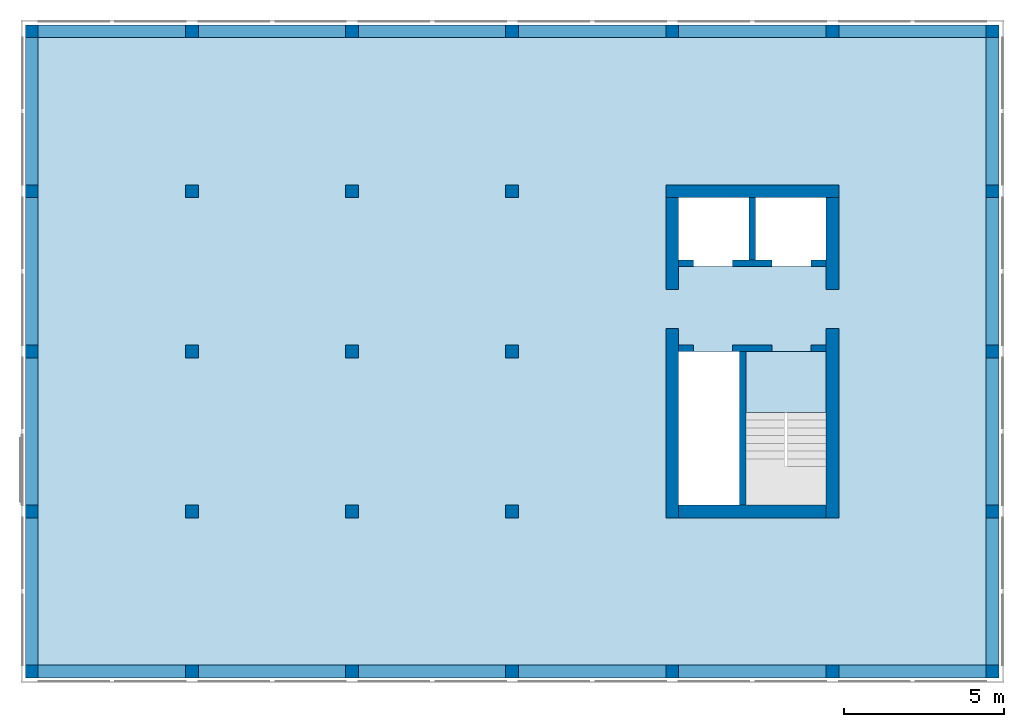
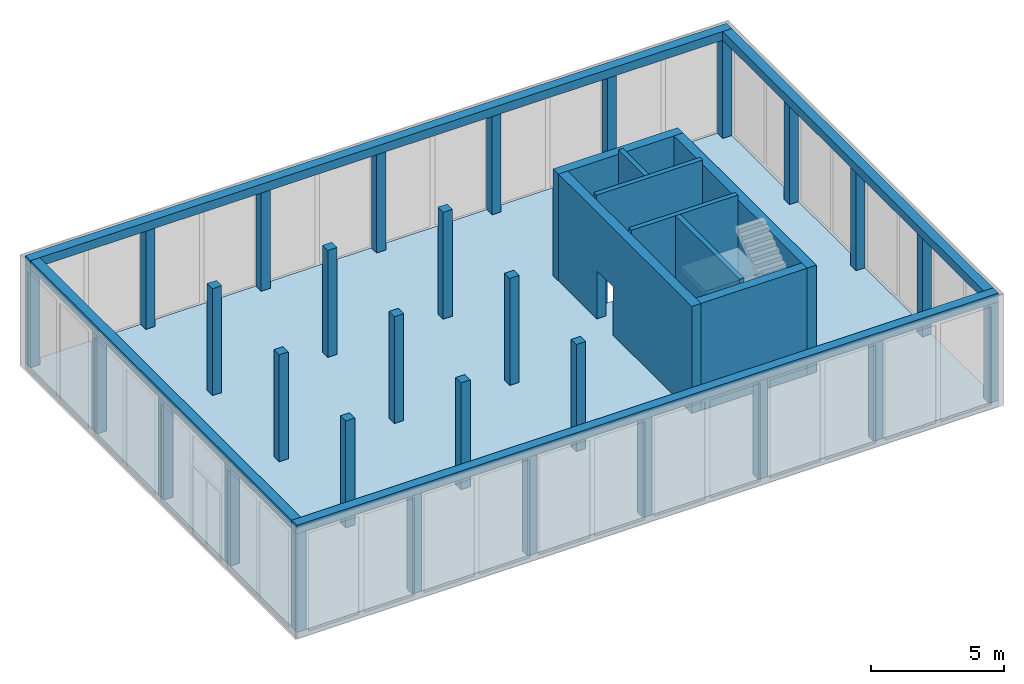
# One storey, part 1 of 5: 29 columns, 8 walls, 4 beams, 2 slabs, 9 openings.
"""IFC2X3 building model written with IfcOpenShell, lengths in metres."""

from ifc_helpers import new_model, entity, si_unit, converted_unit, frame, frame_2d, origin, origin_with_axes, place, context, subcontext, project, spatial, polyline, rectangle, outline, extrude, material, layer, layer_set, layer_usage, element, save


model = new_model("IFC2X3")

# Units and contexts
model_context = context("Model", 3, precision=1e-05, world=origin())
body_context = subcontext(model_context, "Body", "Model", "MODEL_VIEW")
ifc_project = project(units=[si_unit("LENGTHUNIT", "METRE"), si_unit("AREAUNIT", "SQUARE_METRE"), si_unit("VOLUMEUNIT", "CUBIC_METRE"), si_unit("MASSUNIT", "GRAM", prefix="KILO"), converted_unit("PLANEANGLEUNIT", "DEGREE", entity("IfcPlaneAngleMeasure", 0.0174532925199433), si_unit("PLANEANGLEUNIT", "RADIAN"), dimensions=[0, 0, 0, 0, 0, 0, 0])], contexts=[model_context])

# Site, building, storey
site_placement = place(None, origin())
site = spatial("IfcSite", under=ifc_project, at=site_placement, CompositionType="ELEMENT")
building_placement = place(site_placement, origin())
building = spatial("IfcBuilding", under=site, at=building_placement, CompositionType="ELEMENT")
storey_placement = place(building_placement, frame((0.0, 0.0, -0.2)))
storey = spatial("IfcBuildingStorey", under=building, at=storey_placement, Name="Erdgeschoss", CompositionType="ELEMENT", Elevation=-0.2)

# Columns
ifc_material_1 = material(Name="C30/37")
column_1_placement = place(storey_placement, frame((30.0, 15.0, 0.0)))
element("IfcColumn", 1, at=column_1_placement, inside=storey, material=ifc_material_1, context=body_context, shape_type="SweptSolid", body=[
    extrude(rectangle(XDim=0.4, YDim=0.4, at=frame_2d((0.2, 0.2), x_axis=(1.0, 0.0))), origin_with_axes(), (0.0, 0.0, 1.0), 4.5),
])
ifc_material_2 = material(Name="C30/37")
column_2_placement = place(storey_placement, frame((25.0, 0.0, 0.0)))
element("IfcColumn", 2, at=column_2_placement, inside=storey, material=ifc_material_2, context=body_context, shape_type="SweptSolid", body=[
    extrude(rectangle(XDim=0.4, YDim=0.4, at=frame_2d((0.2, 0.2), x_axis=(1.0, 0.0))), origin_with_axes(), (0.0, 0.0, 1.0), 4.5),
])
ifc_material_3 = material(Name="C30/37")
column_3_placement = place(storey_placement, frame((20.0, 0.0, 0.0)))
element("IfcColumn", 3, at=column_3_placement, inside=storey, material=ifc_material_3, context=body_context, shape_type="SweptSolid", body=[
    extrude(rectangle(XDim=0.4, YDim=0.4, at=frame_2d((0.2, 0.2), x_axis=(1.0, 0.0))), origin_with_axes(), (0.0, 0.0, 1.0), 4.5),
])
ifc_material_4 = material(Name="C30/37")
column_4_placement = place(storey_placement, frame((15.0, 0.0, 0.0)))
element("IfcColumn", 4, at=column_4_placement, inside=storey, material=ifc_material_4, context=body_context, shape_type="SweptSolid", body=[
    extrude(rectangle(XDim=0.4, YDim=0.4, at=frame_2d((0.2, 0.2), x_axis=(1.0, 0.0))), origin_with_axes(), (0.0, 0.0, 1.0), 4.5),
])
ifc_material_5 = material(Name="C30/37")
column_5_placement = place(storey_placement, frame((10.0, 0.0, 0.0)))
element("IfcColumn", 5, at=column_5_placement, inside=storey, material=ifc_material_5, context=body_context, shape_type="SweptSolid", body=[
    extrude(rectangle(XDim=0.4, YDim=0.4, at=frame_2d((0.2, 0.2), x_axis=(1.0, 0.0))), origin_with_axes(), (0.0, 0.0, 1.0), 4.5),
])
ifc_material_6 = material(Name="C30/37")
column_6_placement = place(storey_placement, frame((5.0, 0.0, 0.0)))
element("IfcColumn", 6, at=column_6_placement, inside=storey, material=ifc_material_6, context=body_context, shape_type="SweptSolid", body=[
    extrude(rectangle(XDim=0.4, YDim=0.4, at=frame_2d((0.2, 0.2), x_axis=(1.0, 0.0))), origin_with_axes(), (0.0, 0.0, 1.0), 4.5),
])
ifc_material_7 = material(Name="C30/37")
column_7_placement = place(storey_placement, frame((30.0, 10.0, 0.0)))
element("IfcColumn", 7, at=column_7_placement, inside=storey, material=ifc_material_7, context=body_context, shape_type="SweptSolid", body=[
    extrude(rectangle(XDim=0.4, YDim=0.4, at=frame_2d((0.2, 0.2), x_axis=(1.0, 0.0))), origin_with_axes(), (0.0, 0.0, 1.0), 4.5),
])
ifc_material_8 = material(Name="C30/37")
column_8_placement = place(storey_placement, frame((30.0, 5.0, 0.0)))
element("IfcColumn", 8, at=column_8_placement, inside=storey, material=ifc_material_8, context=body_context, shape_type="SweptSolid", body=[
    extrude(rectangle(XDim=0.4, YDim=0.4, at=frame_2d((0.2, 0.2), x_axis=(1.0, 0.0))), origin_with_axes(), (0.0, 0.0, 1.0), 4.5),
])
ifc_material_9 = material(Name="C30/37")
column_9_placement = place(storey_placement, origin())
element("IfcColumn", 9, at=column_9_placement, inside=storey, material=ifc_material_9, context=body_context, shape_type="SweptSolid", body=[
    extrude(rectangle(XDim=0.4, YDim=0.4, at=frame_2d((0.2, 0.2), x_axis=(1.0, 0.0))), origin_with_axes(), (0.0, 0.0, 1.0), 4.5),
])
ifc_material_10 = material(Name="C30/37")
column_10_placement = place(storey_placement, frame((0.0, 15.0, 0.0)))
element("IfcColumn", 10, at=column_10_placement, inside=storey, material=ifc_material_10, context=body_context, shape_type="SweptSolid", body=[
    extrude(rectangle(XDim=0.4, YDim=0.4, at=frame_2d((0.2, 0.2), x_axis=(1.0, 0.0))), origin_with_axes(), (0.0, 0.0, 1.0), 4.5),
])
ifc_material_11 = material(Name="C30/37")
column_11_placement = place(storey_placement, frame((0.0, 5.0, 0.0)))
element("IfcColumn", 11, at=column_11_placement, inside=storey, material=ifc_material_11, context=body_context, shape_type="SweptSolid", body=[
    extrude(rectangle(XDim=0.4, YDim=0.4, at=frame_2d((0.2, 0.2), x_axis=(1.0, 0.0))), origin_with_axes(), (0.0, 0.0, 1.0), 4.5),
])
ifc_material_12 = material(Name="C30/37")
column_12_placement = place(storey_placement, frame((-1.27897692436818e-15, 10.0, 0.0)))
element("IfcColumn", 12, at=column_12_placement, inside=storey, material=ifc_material_12, context=body_context, shape_type="SweptSolid", body=[
    extrude(rectangle(XDim=0.400000000000003, YDim=0.4, at=frame_2d((0.200000000000001, 0.2), x_axis=(1.0, 0.0))), origin_with_axes(), (0.0, 0.0, 1.0), 4.5),
])
ifc_material_13 = material(Name="C30/37")
column_13_placement = place(storey_placement, frame((0.0, 20.0, 0.0)))
element("IfcColumn", 13, at=column_13_placement, inside=storey, material=ifc_material_13, context=body_context, shape_type="SweptSolid", body=[
    extrude(rectangle(XDim=0.4, YDim=0.4, at=frame_2d((0.2, 0.2), x_axis=(1.0, 0.0))), origin_with_axes(), (0.0, 0.0, 1.0), 4.5),
])
ifc_material_14 = material(Name="C30/37")
column_14_placement = place(storey_placement, frame((30.0, 20.0, 0.0)))
element("IfcColumn", 14, at=column_14_placement, inside=storey, material=ifc_material_14, context=body_context, shape_type="SweptSolid", body=[
    extrude(rectangle(XDim=0.4, YDim=0.4, at=frame_2d((0.2, 0.2), x_axis=(1.0, 0.0))), origin_with_axes(), (0.0, 0.0, 1.0), 4.5),
])
ifc_material_15 = material(Name="C30/37")
column_15_placement = place(storey_placement, frame((10.0, 20.0, 0.0)))
element("IfcColumn", 15, at=column_15_placement, inside=storey, material=ifc_material_15, context=body_context, shape_type="SweptSolid", body=[
    extrude(rectangle(XDim=0.4, YDim=0.4, at=frame_2d((0.2, 0.2), x_axis=(1.0, 0.0))), origin_with_axes(), (0.0, 0.0, 1.0), 4.5),
])
ifc_material_16 = material(Name="C30/37")
column_16_placement = place(storey_placement, frame((25.0, 20.0, 0.0)))
element("IfcColumn", 16, at=column_16_placement, inside=storey, material=ifc_material_16, context=body_context, shape_type="SweptSolid", body=[
    extrude(rectangle(XDim=0.4, YDim=0.4, at=frame_2d((0.2, 0.2), x_axis=(1.0, 0.0))), origin_with_axes(), (0.0, 0.0, 1.0), 4.5),
])
ifc_material_17 = material(Name="C30/37")
column_17_placement = place(storey_placement, frame((20.0, 20.0, 0.0)))
element("IfcColumn", 17, at=column_17_placement, inside=storey, material=ifc_material_17, context=body_context, shape_type="SweptSolid", body=[
    extrude(rectangle(XDim=0.4, YDim=0.4, at=frame_2d((0.2, 0.2), x_axis=(1.0, 0.0))), origin_with_axes(), (0.0, 0.0, 1.0), 4.5),
])
ifc_material_18 = material(Name="C30/37")
column_18_placement = place(storey_placement, frame((15.0, 20.0, 0.0)))
element("IfcColumn", 18, at=column_18_placement, inside=storey, material=ifc_material_18, context=body_context, shape_type="SweptSolid", body=[
    extrude(rectangle(XDim=0.4, YDim=0.4, at=frame_2d((0.2, 0.2), x_axis=(1.0, 0.0))), origin_with_axes(), (0.0, 0.0, 1.0), 4.5),
])
ifc_material_19 = material(Name="C30/37")
column_19_placement = place(storey_placement, frame((10.0, 15.0, 0.0)))
element("IfcColumn", 19, at=column_19_placement, inside=storey, material=ifc_material_19, context=body_context, shape_type="SweptSolid", body=[
    extrude(rectangle(XDim=0.4, YDim=0.4, at=frame_2d((0.2, 0.2), x_axis=(1.0, 0.0))), origin_with_axes(), (0.0, 0.0, 1.0), 4.9),
])
ifc_material_20 = material(Name="C30/37")
column_20_placement = place(storey_placement, frame((5.0, 15.0, 0.0)))
element("IfcColumn", 20, at=column_20_placement, inside=storey, material=ifc_material_20, context=body_context, shape_type="SweptSolid", body=[
    extrude(rectangle(XDim=0.4, YDim=0.4, at=frame_2d((0.2, 0.2), x_axis=(1.0, 0.0))), origin_with_axes(), (0.0, 0.0, 1.0), 4.9),
])
ifc_material_21 = material(Name="C30/37")
column_21_placement = place(storey_placement, frame((15.0, 10.0, 0.0)))
element("IfcColumn", 21, at=column_21_placement, inside=storey, material=ifc_material_21, context=body_context, shape_type="SweptSolid", body=[
    extrude(rectangle(XDim=0.4, YDim=0.4, at=frame_2d((0.2, 0.2), x_axis=(1.0, 0.0))), origin_with_axes(), (0.0, 0.0, 1.0), 4.9),
])
ifc_material_22 = material(Name="C30/37")
column_22_placement = place(storey_placement, frame((10.0, 10.0, 0.0)))
element("IfcColumn", 22, at=column_22_placement, inside=storey, material=ifc_material_22, context=body_context, shape_type="SweptSolid", body=[
    extrude(rectangle(XDim=0.4, YDim=0.4, at=frame_2d((0.2, 0.2), x_axis=(1.0, 0.0))), origin_with_axes(), (0.0, 0.0, 1.0), 4.9),
])
ifc_material_23 = material(Name="C30/37")
column_23_placement = place(storey_placement, frame((5.0, 10.0, 0.0)))
element("IfcColumn", 23, at=column_23_placement, inside=storey, material=ifc_material_23, context=body_context, shape_type="SweptSolid", body=[
    extrude(rectangle(XDim=0.4, YDim=0.4, at=frame_2d((0.2, 0.2), x_axis=(1.0, 0.0))), origin_with_axes(), (0.0, 0.0, 1.0), 4.9),
])
ifc_material_24 = material(Name="C30/37")
column_24_placement = place(storey_placement, frame((15.0, 5.0, 0.0)))
element("IfcColumn", 24, at=column_24_placement, inside=storey, material=ifc_material_24, context=body_context, shape_type="SweptSolid", body=[
    extrude(rectangle(XDim=0.4, YDim=0.4, at=frame_2d((0.2, 0.2), x_axis=(1.0, 0.0))), origin_with_axes(), (0.0, 0.0, 1.0), 4.9),
])
ifc_material_25 = material(Name="C30/37")
column_25_placement = place(storey_placement, frame((10.0, 5.0, 0.0)))
element("IfcColumn", 25, at=column_25_placement, inside=storey, material=ifc_material_25, context=body_context, shape_type="SweptSolid", body=[
    extrude(rectangle(XDim=0.4, YDim=0.4, at=frame_2d((0.2, 0.2), x_axis=(1.0, 0.0))), origin_with_axes(), (0.0, 0.0, 1.0), 4.9),
])
ifc_material_26 = material(Name="C30/37")
column_26_placement = place(storey_placement, frame((5.0, 5.0, 0.0)))
element("IfcColumn", 26, at=column_26_placement, inside=storey, material=ifc_material_26, context=body_context, shape_type="SweptSolid", body=[
    extrude(rectangle(XDim=0.4, YDim=0.4, at=frame_2d((0.2, 0.2), x_axis=(1.0, 0.0))), origin_with_axes(), (0.0, 0.0, 1.0), 4.9),
])
ifc_material_27 = material(Name="C30/37")
column_27_placement = place(storey_placement, frame((15.0, 15.0, 0.0)))
element("IfcColumn", 27, at=column_27_placement, inside=storey, material=ifc_material_27, context=body_context, shape_type="SweptSolid", body=[
    extrude(rectangle(XDim=0.4, YDim=0.4, at=frame_2d((0.2, 0.2), x_axis=(1.0, 0.0))), origin_with_axes(), (0.0, 0.0, 1.0), 4.9),
])
ifc_material_28 = material(Name="C30/37")
column_28_placement = place(storey_placement, frame((30.0, -2.8421709430404e-17, 0.0)))
element("IfcColumn", 28, at=column_28_placement, inside=storey, material=ifc_material_28, context=body_context, shape_type="SweptSolid", body=[
    extrude(rectangle(XDim=0.4, YDim=0.4, at=frame_2d((0.2, 0.2), x_axis=(1.0, 0.0))), origin_with_axes(), (0.0, 0.0, 1.0), 4.5),
])
ifc_material_29 = material(Name="C30/37")
column_29_placement = place(storey_placement, frame((5.0, 20.0, 0.0)))
element("IfcColumn", 29, at=column_29_placement, inside=storey, material=ifc_material_29, context=body_context, shape_type="SweptSolid", body=[
    extrude(rectangle(XDim=0.4, YDim=0.4, at=frame_2d((0.2, 0.2), x_axis=(1.0, 0.0))), origin_with_axes(), (0.0, 0.0, 1.0), 4.5),
])

# Beams
ifc_material_30 = material(Name="C30/37")
beam_1_placement = place(storey_placement, frame((-2.8421709430404e-17, 20.0, 4.5)))
element("IfcBeam", 30, at=beam_1_placement, inside=storey, material=ifc_material_30, context=body_context, shape_type="SweptSolid", body=[
    extrude(rectangle(XDim=0.4, YDim=0.4, at=frame_2d((0.2, 0.2), x_axis=(1.0, 0.0))), frame((0.0, 0.0, 0.0), z_axis=(1.0, 0.0, 0.0), x_axis=(0.0, 1.0, 0.0)), (0.0, 0.0, 1.0), 30.4),
])
ifc_material_31 = material(Name="C30/37")
beam_2_placement = place(storey_placement, frame((2.95817792030736e-17, 2.8421709430404e-17, 4.5), z_axis=(0.0, 0.0, 1.0), x_axis=(1.0, -1.86984930463184e-18, 0.0)))
element("IfcBeam", 31, at=beam_2_placement, inside=storey, material=ifc_material_31, context=body_context, shape_type="SweptSolid", body=[
    extrude(rectangle(XDim=0.4, YDim=0.4, at=frame_2d((0.2, 0.2), x_axis=(1.0, 0.0))), frame((0.0, 0.0, 0.0), z_axis=(1.0, 0.0, 0.0), x_axis=(0.0, 1.0, 0.0)), (0.0, 0.0, 1.0), 30.4),
])
ifc_material_32 = material(Name="C30/37")
beam_3_placement = place(storey_placement, frame((-2.8421709430404e-17, 20.0, 4.5), z_axis=(0.0, 0.0, 1.0), x_axis=(2.90017443167388e-18, -1.0, 0.0)))
element("IfcBeam", 32, at=beam_3_placement, inside=storey, material=ifc_material_32, context=body_context, shape_type="SweptSolid", body=[
    extrude(rectangle(XDim=0.4, YDim=0.4, at=frame_2d((0.2, 0.2), x_axis=(1.0, 0.0))), frame((0.0, 0.0, 0.0), z_axis=(1.0, 0.0, 0.0), x_axis=(0.0, 1.0, 0.0)), (0.0, 0.0, 1.0), 19.6),
])
ifc_material_33 = material(Name="C30/37")
beam_4_placement = place(storey_placement, frame((30.4, 0.4, 4.5), z_axis=(0.0, 0.0, 1.0), x_axis=(0.0, 1.0, 0.0)))
element("IfcBeam", 33, at=beam_4_placement, inside=storey, material=ifc_material_33, context=body_context, shape_type="SweptSolid", body=[
    extrude(rectangle(XDim=0.4, YDim=0.4, at=frame_2d((0.2, 0.2), x_axis=(1.0, 0.0))), frame((0.0, 0.0, 0.0), z_axis=(1.0, 0.0, 0.0), x_axis=(0.0, 1.0, 0.0)), (0.0, 0.0, 1.0), 19.6),
])

# Slab, openings
ifc_material_34 = material(Name="C25/30")
slab_1_placement = place(storey_placement, frame((0.0, -2.8421709430404e-17, -0.3)))
slab_1 = element("IfcSlab", 34, at=slab_1_placement, inside=storey, material=ifc_material_34, Name="Geschossdecke", PredefinedType="FLOOR", context=body_context, shape_type="SweptSolid", body=[
    extrude(rectangle(XDim=30.4, YDim=20.4, at=frame_2d((15.2, 10.2), x_axis=(1.0, -9.34924652315921e-19))), frame((0.0, 2.8421709430404e-17, 0.0), z_axis=(0.0, 0.0, 1.0), x_axis=(1.0, 0.0, 0.0)), (0.0, 0.0, 1.0), 0.3),
])
opening_1_placement = place(slab_1_placement, frame((20.4, 5.4, 0.0)))
element("IfcOpeningElement", 35, at=opening_1_placement, cuts=slab_1, ObjectType="Opening", context=body_context, shape_type="SweptSolid", body=[
    extrude(rectangle(XDim=4.8, YDim=2.1, at=frame_2d((1.81898940354586e-15, 0.0), x_axis=(0.0, -1.0))), frame((1.05, 2.4, 0.0), z_axis=(0.0, 0.0, 1.0), x_axis=(1.0, 0.0, 0.0)), (0.0, 0.0, 1.0), 0.3),
])
opening_2_placement = place(slab_1_placement, frame((22.5, 5.4, 0.0)))
element("IfcOpeningElement", 36, at=opening_2_placement, cuts=slab_1, ObjectType="Opening", context=body_context, shape_type="SweptSolid", body=[
    extrude(rectangle(XDim=3.5401, YDim=2.5, at=frame_2d((0.0, 0.0), x_axis=(0.0, -1.0))), frame((1.25, 1.77005, 0.0), z_axis=(0.0, 0.0, 1.0), x_axis=(1.0, 0.0, 0.0)), (0.0, 0.0, 1.0), 0.3),
])
opening_3_placement = place(slab_1_placement, frame((20.4, 12.85, 0.0)))
element("IfcOpeningElement", 37, at=opening_3_placement, cuts=slab_1, ObjectType="Opening", context=body_context, shape_type="SweptSolid", body=[
    extrude(rectangle(XDim=2.15, YDim=4.6, at=frame_2d((1.81898940354586e-15, 0.0), x_axis=(0.0, -1.0))), frame((2.3, 1.075, 0.0), z_axis=(0.0, 0.0, 1.0), x_axis=(1.0, 0.0, 0.0)), (0.0, 0.0, 1.0), 0.3),
])

# Slab
ifc_material_35 = material(Name="C25/30")
slab_2_placement = place(storey_placement, frame((22.5, 8.30000000000001, 2.52)))
element("IfcSlab", 38, at=slab_2_placement, inside=storey, material=ifc_material_35, PredefinedType="FLOOR", context=body_context, shape_type="SweptSolid", body=[
    extrude(rectangle(XDim=2.5, YDim=1.89999999999999, at=frame_2d((1.25, 0.949999999999998), x_axis=(1.0, 0.0))), origin_with_axes(), (0.0, 0.0, 1.0), 0.2),
])

# Wall, opening
ifc_material_36 = material(Name="C25/30")
ifc_layer_1 = layer(ifc_material_36, 0.4)
ifc_layer_set_1 = layer_set([ifc_layer_1])
ifc_layer_usage_1 = layer_usage(ifc_layer_set_1, "AXIS2", "POSITIVE", -0.2)
wall_1_placement = place(storey_placement, frame((20.4, 5.0, 0.0), z_axis=(0.0, 0.0, 1.0), x_axis=(0.0, 1.0, 0.0)))
wall_1 = element("IfcWallStandardCase", 39, at=wall_1_placement, inside=storey, material=ifc_layer_usage_1, context=body_context, shape_type="SweptSolid", body=[
    extrude(rectangle(XDim=10.0, YDim=0.4, at=frame_2d((5.0, 0.2), x_axis=(1.0, 0.0))), origin_with_axes(), (0.0, 0.0, 1.0), 4.9),
])
opening_4_placement = place(wall_1_placement, frame((5.92, 0.0, 0.0), z_axis=(0.0, 1.0, 0.0), x_axis=(0.0, 0.0, 1.0)))
element("IfcOpeningElement", 40, at=opening_4_placement, cuts=wall_1, ObjectType="Opening", context=body_context, shape_type="SweptSolid", body=[
    extrude(outline(polyline([(0.0, 1.21), (2.21, 1.21), (2.21, 0.0), (0.0, 0.0), (0.0, 1.21)])), origin_with_axes(), (0.0, 0.0, 1.0), 0.4),
])

# Walls
ifc_material_37 = material(Name="C25/30")
ifc_layer_2 = layer(ifc_material_37, 0.4)
ifc_layer_set_2 = layer_set([ifc_layer_2])
ifc_layer_usage_2 = layer_usage(ifc_layer_set_2, "AXIS2", "POSITIVE", -0.2)
wall_2_placement = place(storey_placement, frame((20.0, 15.0, 0.0)))
element("IfcWallStandardCase", 41, at=wall_2_placement, inside=storey, material=ifc_layer_usage_2, context=body_context, shape_type="SweptSolid", body=[
    extrude(rectangle(XDim=5.4, YDim=0.4, at=frame_2d((2.7, 0.2), x_axis=(1.0, 0.0))), origin_with_axes(), (0.0, 0.0, 1.0), 4.9),
])
ifc_material_38 = material(Name="C25/30")
ifc_layer_3 = layer(ifc_material_38, 0.2)
ifc_layer_set_3 = layer_set([ifc_layer_3])
ifc_layer_usage_3 = layer_usage(ifc_layer_set_3, "AXIS2", "POSITIVE", -0.2)
wall_3_placement = place(storey_placement, frame((22.3, 10.2, 0.0), z_axis=(0.0, 0.0, 1.0), x_axis=(0.0, -1.0, 0.0)))
element("IfcWallStandardCase", 42, at=wall_3_placement, inside=storey, material=ifc_layer_usage_3, Name="IW Beton", context=body_context, shape_type="SweptSolid", body=[
    extrude(rectangle(XDim=4.8, YDim=0.2, at=frame_2d((2.4, 0.1), x_axis=(1.0, 0.0))), origin_with_axes(), (0.0, 0.0, 1.0), 5.1),
])

# Wall, openings
ifc_material_39 = material(Name="C25/30")
ifc_layer_4 = layer(ifc_material_39, 0.2)
ifc_layer_set_4 = layer_set([ifc_layer_4])
ifc_layer_usage_4 = layer_usage(ifc_layer_set_4, "AXIS2", "POSITIVE", -0.2)
wall_4_placement = place(storey_placement, frame((25.0, 10.4, 0.0), z_axis=(0.0, 0.0, 1.0), x_axis=(-1.0, 0.0, 0.0)))
wall_4 = element("IfcWallStandardCase", 43, at=wall_4_placement, inside=storey, material=ifc_layer_usage_4, Name="IW Beton", context=body_context, shape_type="SweptSolid", body=[
    extrude(rectangle(XDim=4.6, YDim=0.2, at=frame_2d((2.3, 0.1), x_axis=(1.0, 0.0))), origin_with_axes(), (0.0, 0.0, 1.0), 5.1),
])
opening_5_placement = place(wall_4_placement, frame((1.68, 0.2, 0.0), z_axis=(0.0, -1.0, 0.0), x_axis=(0.0, 0.0, 1.0)))
element("IfcOpeningElement", 44, at=opening_5_placement, cuts=wall_4, ObjectType="Opening", context=body_context, shape_type="SweptSolid", body=[
    extrude(outline(polyline([(0.0, 1.21), (2.21, 1.21), (2.21, 0.0), (0.0, 0.0), (0.0, 1.21)])), origin_with_axes(), (0.0, 0.0, 1.0), 0.2),
])
opening_6_placement = place(wall_4_placement, frame((4.13, 0.2, 0.0), z_axis=(0.0, -1.0, 0.0), x_axis=(0.0, 0.0, 1.0)))
element("IfcOpeningElement", 45, at=opening_6_placement, cuts=wall_4, ObjectType="Opening", context=body_context, shape_type="SweptSolid", body=[
    extrude(outline(polyline([(0.0, 1.21), (2.21, 1.21), (2.21, 0.0), (0.0, 0.0), (0.0, 1.21)])), origin_with_axes(), (0.0, 0.0, 1.0), 0.2),
])

ifc_material_40 = material(Name="C25/30")
ifc_layer_5 = layer(ifc_material_40, 0.2)
ifc_layer_set_5 = layer_set([ifc_layer_5])
ifc_layer_usage_5 = layer_usage(ifc_layer_set_5, "AXIS2", "POSITIVE", -0.2)
wall_5_placement = place(storey_placement, frame((25.0, 13.05, 0.0), z_axis=(0.0, 0.0, 1.0), x_axis=(-1.0, 0.0, 0.0)))
wall_5 = element("IfcWallStandardCase", 46, at=wall_5_placement, inside=storey, material=ifc_layer_usage_5, Name="IW Beton", context=body_context, shape_type="SweptSolid", body=[
    extrude(rectangle(XDim=4.6, YDim=0.2, at=frame_2d((2.3, 0.1), x_axis=(1.0, 0.0))), origin_with_axes(), (0.0, 0.0, 1.0), 5.1),
])
opening_7_placement = place(wall_5_placement, frame((4.13, 0.2, 0.0), z_axis=(0.0, -1.0, 0.0), x_axis=(0.0, 0.0, 1.0)))
element("IfcOpeningElement", 47, at=opening_7_placement, cuts=wall_5, ObjectType="Opening", context=body_context, shape_type="SweptSolid", body=[
    extrude(outline(polyline([(0.0, 1.21), (2.21, 1.21), (2.21, 0.0), (0.0, 0.0), (0.0, 1.21)])), origin_with_axes(), (0.0, 0.0, 1.0), 0.2),
])
opening_8_placement = place(wall_5_placement, frame((1.68, 0.2, 0.0), z_axis=(0.0, -1.0, 0.0), x_axis=(0.0, 0.0, 1.0)))
element("IfcOpeningElement", 48, at=opening_8_placement, cuts=wall_5, ObjectType="Opening", context=body_context, shape_type="SweptSolid", body=[
    extrude(outline(polyline([(0.0, 1.21), (2.21, 1.21), (2.21, 0.0), (0.0, 0.0), (0.0, 1.21)])), origin_with_axes(), (0.0, 0.0, 1.0), 0.2),
])

# Walls
ifc_material_41 = material(Name="C25/30")
ifc_layer_6 = layer(ifc_material_41, 0.2)
ifc_layer_set_6 = layer_set([ifc_layer_6])
ifc_layer_usage_6 = layer_usage(ifc_layer_set_6, "AXIS2", "POSITIVE", -0.2)
wall_6_placement = place(storey_placement, frame((22.6, 15.0, 0.0), z_axis=(0.0, 0.0, 1.0), x_axis=(0.0, -1.0, 0.0)))
element("IfcWallStandardCase", 49, at=wall_6_placement, inside=storey, material=ifc_layer_usage_6, Name="IW Beton", context=body_context, shape_type="SweptSolid", body=[
    extrude(rectangle(XDim=1.95, YDim=0.2, at=frame_2d((0.975, 0.1), x_axis=(1.0, 0.0))), origin_with_axes(), (0.0, 0.0, 1.0), 5.1),
])
ifc_material_42 = material(Name="C25/30")
ifc_layer_7 = layer(ifc_material_42, 0.4)
ifc_layer_set_7 = layer_set([ifc_layer_7])
ifc_layer_usage_7 = layer_usage(ifc_layer_set_7, "AXIS2", "POSITIVE", -0.2)
wall_7_placement = place(storey_placement, frame((25.0, 5.4, 0.0), z_axis=(0.0, 0.0, 1.0), x_axis=(-1.0, 0.0, 0.0)))
element("IfcWallStandardCase", 50, at=wall_7_placement, inside=storey, material=ifc_layer_usage_7, context=body_context, shape_type="SweptSolid", body=[
    extrude(rectangle(XDim=4.6, YDim=0.4, at=frame_2d((2.3, 0.2), x_axis=(1.0, 0.0))), origin_with_axes(), (0.0, 0.0, 1.0), 4.9),
])

# Wall, opening
ifc_material_43 = material(Name="C25/30")
ifc_layer_8 = layer(ifc_material_43, 0.4)
ifc_layer_set_8 = layer_set([ifc_layer_8])
ifc_layer_usage_8 = layer_usage(ifc_layer_set_8, "AXIS2", "POSITIVE", -0.2)
wall_8_placement = place(storey_placement, frame((25.0, 15.0, 0.0), z_axis=(0.0, 0.0, 1.0), x_axis=(0.0, -1.0, 0.0)))
wall_8 = element("IfcWallStandardCase", 51, at=wall_8_placement, inside=storey, material=ifc_layer_usage_8, context=body_context, shape_type="SweptSolid", body=[
    extrude(rectangle(XDim=10.0, YDim=0.4, at=frame_2d((5.0, 0.2), x_axis=(1.0, 0.0))), origin_with_axes(), (0.0, 0.0, 1.0), 4.9),
])
opening_9_placement = place(wall_8_placement, frame((4.08, 0.4, 0.0), z_axis=(0.0, -1.0, 0.0), x_axis=(0.0, 0.0, 1.0)))
element("IfcOpeningElement", 52, at=opening_9_placement, cuts=wall_8, ObjectType="Opening", context=body_context, shape_type="SweptSolid", body=[
    extrude(outline(polyline([(0.0, 1.21), (2.21, 1.21), (2.21, 0.0), (0.0, 0.0), (0.0, 1.21)])), origin_with_axes(), (0.0, 0.0, 1.0), 0.4),
])

save(model, "model.ifc")
